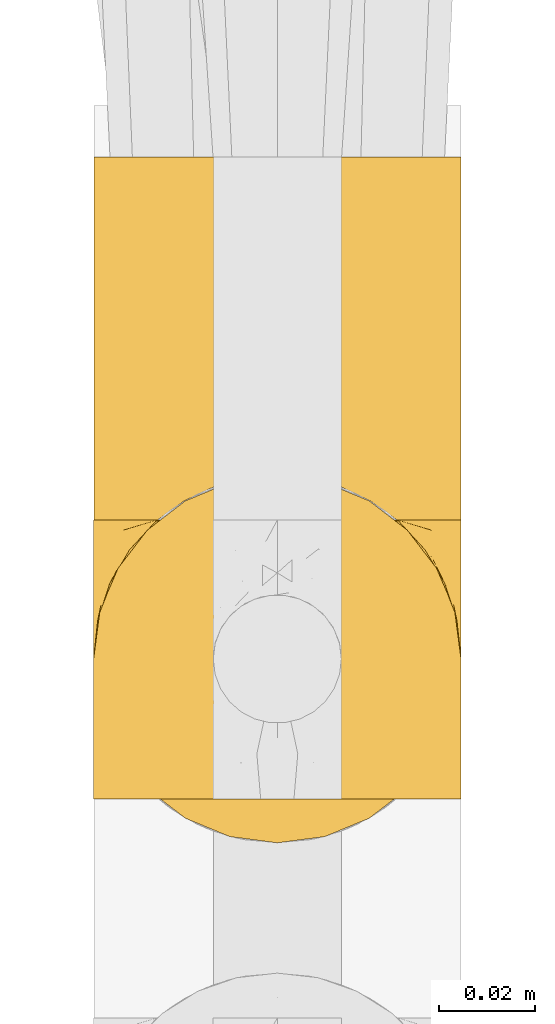
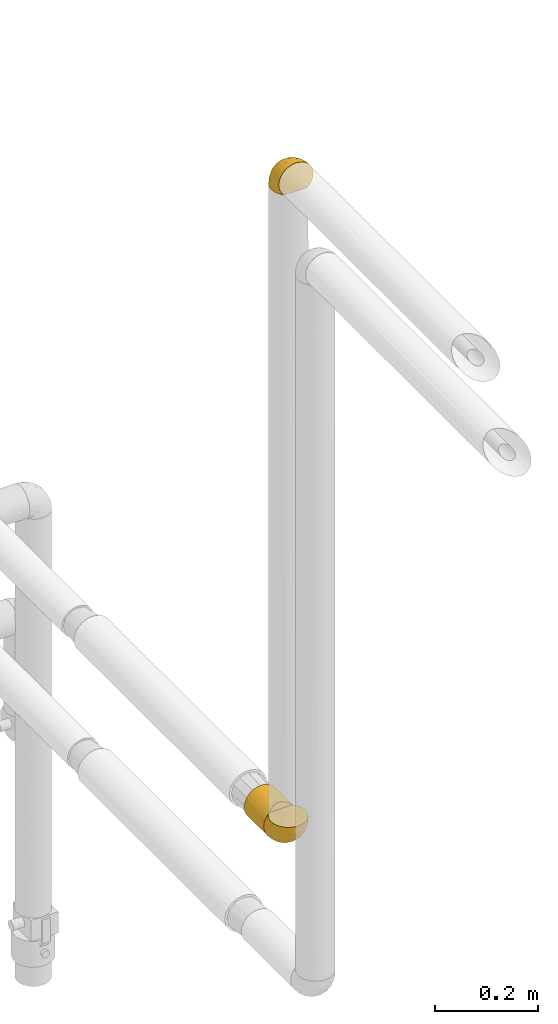
# One storey, part 61 of 827: 3 coverings.
"""IFC2X3 building model written with IfcOpenShell, lengths in millimetres."""

import ifcopenshell
import ifcopenshell.guid

model = None  # the IFC model being written
_history = None  # IfcOwnerHistory: only IFC2X3 demands one
_inside = {}  # id of a spatial element -> (the spatial element, [elements in it])
_under = {}  # id of a project, library or spatial element -> (it, [spatial elements below it])
_declared = {}  # id of a project -> (the project, [libraries it declares])
_typed = {}  # id of a type object -> (the type object, [elements of that type])
_made_of = {}  # id of a material, layer set ... -> (it, [elements and type objects made of it])


def new_model(schema):
    """Start an empty IFC model of exactly this schema.

    Asked for "IFC4X3", IfcOpenShell would pick the latest addendum, in which some entities
    have other attributes; the version numbers below select the first issue.
    IFC2X3 requires an IfcOwnerHistory on every rooted entity: one is made here for all.
    """
    global model, _history
    if schema == "IFC4X3":
        model = ifcopenshell.file(schema_version=(4, 3, 0, 0))
    else:
        model = ifcopenshell.file(schema=schema)
    _inside.clear()
    _under.clear()
    _declared.clear()
    _typed.clear()
    _made_of.clear()
    _history = None
    if model.schema == "IFC2X3":
        org = make("IfcOrganization", Name="unknown")
        user = make(
            "IfcPersonAndOrganization",
            ThePerson=make("IfcPerson", FamilyName="unknown"),
            TheOrganization=org,
        )
        app = make(
            "IfcApplication",
            ApplicationDeveloper=org,
            Version="unknown",
            ApplicationFullName="unknown",
            ApplicationIdentifier="unknown",
        )
        _history = make(
            "IfcOwnerHistory",
            OwningUser=user,
            OwningApplication=app,
            ChangeAction="ADDED",
            CreationDate=0,
        )
    return model


def make(cls, **values):
    """One entity of the class cls with the attributes given. An attribute that is None is left unset."""
    return model.create_entity(
        cls, **{name: value for name, value in values.items() if value is not None}
    )


def entity(cls, *values):
    """Any entity or typed value of the class cls, its attributes in the order of the schema. None: left unset."""
    e = model.create_entity(cls)
    for i, value in enumerate(values):
        if value is not None:
            e[i] = value
    return e


def rooted(cls, **values):
    """An entity with a GlobalId (a new one), such as an element, a storey or a relation."""
    return make(cls, GlobalId=ifcopenshell.guid.new(), OwnerHistory=_history, **values)


def si_unit(unit_type, name, prefix=None):
    """IfcSIUnit, for example si_unit("LENGTHUNIT", "METRE", prefix="MILLI")."""
    return make("IfcSIUnit", UnitType=unit_type, Prefix=prefix, Name=name)


def converted_unit(unit_type, name, factor, base, dimensions=None, offset=None):
    """IfcConversionBasedUnit, such as the inch: factor (a typed value) times the base unit."""
    return make(
        "IfcConversionBasedUnit"
        if offset is None
        else "IfcConversionBasedUnitWithOffset",
        ConversionOffset=offset,
        Dimensions=None
        if dimensions is None
        else entity("IfcDimensionalExponents", *dimensions),
        UnitType=unit_type,
        Name=name,
        ConversionFactor=make(
            "IfcMeasureWithUnit", ValueComponent=factor, UnitComponent=base
        ),
    )


def derived_unit(unit_type, elements):
    """IfcDerivedUnit: a product of units, each with its exponent."""
    return make(
        "IfcDerivedUnit",
        Elements=[
            make("IfcDerivedUnitElement", Unit=unit, Exponent=power)
            for unit, power in elements
        ],
        UnitType=unit_type,
    )


def assignment(units):
    """IfcUnitAssignment: the units of a project."""
    return None if units is None else make("IfcUnitAssignment", Units=units)


def point(xyz):
    """IfcCartesianPoint."""
    return None if xyz is None else make("IfcCartesianPoint", Coordinates=xyz)


def direction(xyz):
    """IfcDirection."""
    return None if xyz is None else make("IfcDirection", DirectionRatios=xyz)


def frame(location, z_axis=None, x_axis=None):
    """IfcAxis2Placement3D, a coordinate frame: its origin and axes. An axis left out is left unset."""
    return make(
        "IfcAxis2Placement3D",
        Location=point(location),
        Axis=direction(z_axis),
        RefDirection=direction(x_axis),
    )


def origin():
    """The frame at (0, 0, 0) with its axes left unset."""
    return frame((0.0, 0.0, 0.0))


def place(relative_to, where):
    """IfcLocalPlacement: puts the frame where relative to a parent placement (None: the world)."""
    return make(
        "IfcLocalPlacement", PlacementRelTo=relative_to, RelativePlacement=where
    )


def context(
    kind, dimensions, precision=None, world=None, true_north=None, identifier=None
):
    """IfcGeometricRepresentationContext, for example the 3D "Model" context."""
    return make(
        "IfcGeometricRepresentationContext",
        ContextIdentifier=identifier,
        ContextType=kind,
        CoordinateSpaceDimension=dimensions,
        Precision=precision,
        WorldCoordinateSystem=world,
        TrueNorth=true_north,
    )


def subcontext(parent, identifier, kind, view, scale=None):
    """IfcGeometricRepresentationSubContext, for example "Body" below "Model"."""
    return make(
        "IfcGeometricRepresentationSubContext",
        ContextIdentifier=identifier,
        ContextType=kind,
        ParentContext=parent,
        TargetScale=scale,
        TargetView=view,
    )


def project(units=None, contexts=None):
    """IfcProject with its units and contexts."""
    return rooted(
        "IfcProject",
        Name="project",
        RepresentationContexts=contexts,
        UnitsInContext=assignment(units),
    )


def spatial(cls, under=None, at=None, **own):
    """A site, building, storey or space (cls), placed at a placement, below another one or the project."""
    s = rooted(cls, ObjectPlacement=at, **own)
    if under is not None:
        _under.setdefault(under.id(), (under, []))[1].append(s)
    return s


def faces_of(points, faces, orient=None, outer=None):
    """IfcFace entities. A face is a list of loops; a loop is a list of indices into points, from 0.

    orient and outer hold one flag for each loop. By default every Orientation is true, the
    first loop of a face is its IfcFaceOuterBound and the others are IfcFaceBound.
    """
    made = []
    for i, loops in enumerate(faces):
        bounds = []
        for j, loop in enumerate(loops):
            is_outer = j == 0 if outer is None else outer[i][j]
            bounds.append(
                make(
                    "IfcFaceOuterBound" if is_outer else "IfcFaceBound",
                    Bound=make("IfcPolyLoop", Polygon=[points[k] for k in loop]),
                    Orientation=True if orient is None else orient[i][j],
                )
            )
        made.append(make("IfcFace", Bounds=bounds))
    return made


def faceted_brep(points, faces, orient=None, outer=None, voids=None):
    """IfcFacetedBrep: a solid bounded by flat faces; with voids (closed shells), ...WithVoids."""
    shared = [point(p) for p in points]
    hull = make("IfcClosedShell", CfsFaces=faces_of(shared, faces, orient, outer))
    if voids is None:
        return make("IfcFacetedBrep", Outer=hull)
    return make(
        "IfcFacetedBrepWithVoids",
        Outer=hull,
        Voids=[
            make(cls, CfsFaces=faces_of(shared, fs, o, b)) for cls, fs, o, b in voids
        ],
    )


def shape(context_of_items, identifier, shape_type, items):
    """IfcShapeRepresentation: the items that make up one representation, for example the "Body"."""
    return make(
        "IfcShapeRepresentation",
        ContextOfItems=context_of_items,
        RepresentationIdentifier=identifier,
        RepresentationType=shape_type,
        Items=items,
    )


def made_of(thing, what):
    """Note that an element or type object is made of a material, layer set ...; save() writes the relation."""
    if what is not None:
        _made_of.setdefault(what.id(), (what, []))[1].append(thing)
    return thing


def element(
    cls,
    number,
    at=None,
    inside=None,
    cuts=None,
    type_object=None,
    material=None,
    context=None,
    identifier="Body",
    shape_type=None,
    held_by="IfcProductDefinitionShape",
    body=None,
    shapes=None,
    **own,
):
    """One element of the class cls, such as IfcWall. Its Tag is "e" and its number.

    at: its placement. inside: the storey or other place that contains it. cuts: it is an
    opening in that element (IfcRelVoidsElement). A single representation is given by context,
    identifier, shape_type and body (its items); several are given by shapes. held_by: the class
    of the entity that holds the representations. save() writes the other relations.
    """
    e = rooted(cls, Tag="e%d" % number, ObjectPlacement=at, **own)
    if body is not None:
        shapes = [shape(context, identifier, shape_type, body)]
    if shapes is not None:
        e.Representation = make(held_by, Representations=shapes)
    if inside is not None:
        _inside.setdefault(inside.id(), (inside, []))[1].append(e)
    if cuts is not None:
        rooted(
            "IfcRelVoidsElement", RelatingBuildingElement=cuts, RelatedOpeningElement=e
        )
    if type_object is not None:
        _typed.setdefault(type_object.id(), (type_object, []))[1].append(e)
    return made_of(e, material)


def aggregate(whole, parts):
    """IfcRelAggregates: a whole, such as a stair, and the parts it consists of."""
    return rooted("IfcRelAggregates", RelatingObject=whole, RelatedObjects=parts)


def save(model, path):
    """Write the relations noted so far, then the file.

    IfcRelAggregates (storeys below a building ...), IfcRelContainedInSpatialStructure (elements
    in a storey), IfcRelDefinesByType, IfcRelAssociatesMaterial and IfcRelDeclares: one each for
    every whole, place, type object, material and project.
    """
    for whole, parts in _under.values():
        aggregate(whole, parts)
    for where, things in _inside.values():
        rooted(
            "IfcRelContainedInSpatialStructure",
            RelatedElements=things,
            RelatingStructure=where,
        )
    for kind, things in _typed.values():
        rooted("IfcRelDefinesByType", RelatedObjects=things, RelatingType=kind)
    for what, things in _made_of.values():
        rooted("IfcRelAssociatesMaterial", RelatedObjects=things, RelatingMaterial=what)
    for by, libraries in _declared.values():
        rooted("IfcRelDeclares", RelatingContext=by, RelatedDefinitions=libraries)
    model.write(path)


model = new_model("IFC2X3")

# Units and contexts
model_context = context("Model", 3, precision=0.01, world=origin(), true_north=direction((6.12303176911189e-17, 1.0)))
body_context = subcontext(model_context, "Body", "Model", "MODEL_VIEW")
ifc_project = project(units=[si_unit("LENGTHUNIT", "METRE", prefix="MILLI"), si_unit("AREAUNIT", "SQUARE_METRE"), si_unit("VOLUMEUNIT", "CUBIC_METRE"), converted_unit("PLANEANGLEUNIT", "DEGREE", entity("IfcRatioMeasure", 0.0174532925199433), si_unit("PLANEANGLEUNIT", "RADIAN"), dimensions=[0, 0, 0, 0, 0, 0, 0]), si_unit("MASSUNIT", "GRAM", prefix="KILO"), derived_unit("MASSDENSITYUNIT", [(si_unit("MASSUNIT", "GRAM", prefix="KILO"), 1), (si_unit("LENGTHUNIT", "METRE"), -3)]), derived_unit("MOMENTOFINERTIAUNIT", [(si_unit("LENGTHUNIT", "METRE"), 4)]), si_unit("TIMEUNIT", "SECOND"), si_unit("FREQUENCYUNIT", "HERTZ"), si_unit("THERMODYNAMICTEMPERATUREUNIT", "DEGREE_CELSIUS"), derived_unit("THERMALTRANSMITTANCEUNIT", [(si_unit("MASSUNIT", "GRAM", prefix="KILO"), 1), (si_unit("THERMODYNAMICTEMPERATUREUNIT", "KELVIN"), -1), (si_unit("TIMEUNIT", "SECOND"), -3)]), derived_unit("VOLUMETRICFLOWRATEUNIT", [(si_unit("LENGTHUNIT", "METRE"), 3), (si_unit("TIMEUNIT", "SECOND"), -1)]), derived_unit("MASSFLOWRATEUNIT", [(si_unit("MASSUNIT", "GRAM", prefix="KILO"), 1), (si_unit("TIMEUNIT", "SECOND"), -1)]), derived_unit("ROTATIONALFREQUENCYUNIT", [(si_unit("TIMEUNIT", "SECOND"), -1)]), si_unit("ELECTRICCURRENTUNIT", "AMPERE"), si_unit("ELECTRICVOLTAGEUNIT", "VOLT"), si_unit("POWERUNIT", "WATT"), si_unit("FORCEUNIT", "NEWTON", prefix="KILO"), si_unit("ILLUMINANCEUNIT", "LUX"), si_unit("LUMINOUSFLUXUNIT", "LUMEN"), si_unit("LUMINOUSINTENSITYUNIT", "CANDELA"), derived_unit("USERDEFINED", [(si_unit("MASSUNIT", "GRAM", prefix="KILO"), -1), (si_unit("LENGTHUNIT", "METRE"), -2), (si_unit("TIMEUNIT", "SECOND"), 3), (si_unit("LUMINOUSFLUXUNIT", "LUMEN"), 1)]), derived_unit("LINEARVELOCITYUNIT", [(si_unit("LENGTHUNIT", "METRE"), 1), (si_unit("TIMEUNIT", "SECOND"), -1)]), si_unit("PRESSUREUNIT", "PASCAL"), derived_unit("USERDEFINED", [(si_unit("LENGTHUNIT", "METRE"), -2), (si_unit("MASSUNIT", "GRAM", prefix="KILO"), 1), (si_unit("TIMEUNIT", "SECOND"), -2)]), derived_unit("LINEARFORCEUNIT", [(si_unit("MASSUNIT", "GRAM", prefix="KILO"), 1), (si_unit("LENGTHUNIT", "METRE"), 1), (si_unit("TIMEUNIT", "SECOND"), -2), (si_unit("LENGTHUNIT", "METRE"), -1)]), derived_unit("PLANARFORCEUNIT", [(si_unit("MASSUNIT", "GRAM", prefix="KILO"), 1), (si_unit("LENGTHUNIT", "METRE"), 1), (si_unit("TIMEUNIT", "SECOND"), -2), (si_unit("LENGTHUNIT", "METRE"), -2)])], contexts=[model_context])

# Site, building, storey
site_placement = place(None, origin())
site = spatial("IfcSite", under=ifc_project, at=site_placement, CompositionType="ELEMENT")
building_placement = place(site_placement, origin())
building = spatial("IfcBuilding", under=site, at=building_placement, CompositionType="ELEMENT")
storey_placement = place(building_placement, frame((0.0, 0.0, 28200.0)))
storey = spatial("IfcBuildingStorey", under=building, at=storey_placement, Name="08", CompositionType="ELEMENT", Elevation=28200.0)

# Coverings
covering_1_placement = place(storey_placement, frame((13238.8, 11192.04, 1260.0)))
element("IfcCovering", 1, at=covering_1_placement, inside=storey, Name=":ADSK_", ObjectType=":ADSK_", PredefinedType="INSULATION", context=body_context, shape_type="Brep", body=[
    faceted_brep([(20.8, 1.6, 6.74), (30.06, 1.6, 2.9), (40.0, 1.6, 1.6), (49.93, 1.6, 2.9), (59.2, 1.6, 6.74), (67.15, 1.6, 12.84), (73.25, 1.6, 20.8), (77.09, 1.6, 30.06), (78.4, 1.6, 40.0), (77.51, 1.6, 48.2), (74.9, 1.6, 56.01), (70.68, 1.6, 63.08), (65.05, 1.6, 69.1), (14.94, 1.6, 69.1), (9.31, 1.6, 63.08), (5.09, 1.6, 56.01), (2.48, 1.6, 48.2), (1.6, 1.6, 40.0), (2.9, 1.6, 30.06), (6.74, 1.6, 20.8), (12.84, 1.6, 12.84), (20.8, 77.5, 6.74), (12.84, 77.5, 12.84), (6.74, 77.5, 20.8), (2.9, 77.5, 30.06), (1.6, 77.5, 40.0), (2.9, 77.5, 49.93), (6.74, 77.5, 59.2), (12.84, 77.5, 67.15), (20.8, 77.5, 73.25), (30.06, 77.5, 77.09), (40.0, 77.5, 78.4), (49.93, 77.5, 77.09), (59.2, 77.5, 73.25), (67.15, 77.5, 67.15), (73.25, 77.5, 59.2), (77.09, 77.5, 49.93), (78.4, 77.5, 40.0), (77.09, 77.5, 30.06), (73.25, 77.5, 20.8), (67.15, 77.5, 12.84), (59.2, 77.5, 6.74), (49.93, 77.5, 2.9), (40.0, 77.5, 1.6), (30.06, 77.5, 2.9), (53.36, 8.5, 76.0), (46.78, 10.29, 77.79), (40.0, 10.9, 78.4), (59.51, 5.57, 73.07), (33.21, 10.29, 77.79), (26.63, 8.5, 76.0), (20.48, 5.57, 73.07)], [[[0, 1, 2, 3, 4, 5, 6, 7, 8, 9, 10, 11, 12, 13, 14, 15, 16, 17, 18, 19, 20]], [[21, 22, 23, 24, 25, 26, 27, 28, 29, 30, 31, 32, 33, 34, 35, 36, 37, 38, 39, 40, 41, 42, 43, 44]], [[24, 23, 19, 18]], [[25, 24, 18, 17]], [[20, 19, 23, 22]], [[1, 0, 21, 44]], [[2, 1, 44, 43]], [[22, 21, 0, 20]], [[3, 2, 43, 42]], [[4, 3, 42, 41]], [[41, 40, 5, 4]], [[7, 6, 39, 38]], [[8, 7, 38, 37]], [[40, 39, 6, 5]], [[9, 37, 36]], [[10, 36, 35]], [[11, 35, 34]], [[8, 37, 9]], [[9, 36, 10]], [[35, 11, 10]], [[34, 12, 11]], [[45, 33, 32]], [[32, 31, 46]], [[47, 46, 31]], [[48, 12, 33]], [[46, 45, 32]], [[48, 33, 45]], [[33, 12, 34]], [[49, 47, 31]], [[49, 31, 30]], [[50, 30, 29]], [[50, 49, 30]], [[13, 51, 29]], [[50, 29, 51]], [[29, 28, 13]], [[14, 28, 27]], [[15, 27, 26]], [[16, 26, 25]], [[14, 27, 15]], [[15, 26, 16]], [[25, 17, 16]], [[28, 14, 13]], [[48, 45, 46, 47, 49, 50, 51, 13, 12]]]),
])
covering_2_placement = place(storey_placement, frame((13238.75, 11124.49, 1259.95)))
element("IfcCovering", 2, at=covering_2_placement, inside=storey, Name=":ADSK_", ObjectType=":ADSK_", PredefinedType="INSULATION", context=body_context, shape_type="Brep", body=[
    faceted_brep([(74.68, 69.15, 23.36), (70.1, 69.15, 16.07), (64.01, 69.15, 9.98), (56.72, 69.15, 5.4), (48.6, 69.15, 2.56), (40.05, 69.15, 1.6), (31.49, 69.15, 2.56), (23.36, 69.15, 5.41), (16.07, 69.15, 9.99), (9.98, 69.15, 16.08), (5.4, 69.15, 23.37), (2.56, 69.15, 31.49), (1.6, 69.15, 40.05), (2.46, 69.15, 48.15), (5.01, 69.15, 55.88), (9.13, 69.15, 62.9), (14.62, 69.15, 68.89), (16.82, 69.15, 68.89), (18.56, 69.15, 68.89), (20.52, 69.15, 68.89), (22.49, 69.15, 68.89), (24.46, 69.15, 68.89), (26.42, 69.15, 68.89), (28.39, 69.15, 68.89), (30.36, 69.15, 68.89), (32.55, 69.15, 68.89), (34.75, 69.15, 68.89), (36.94, 69.15, 68.89), (39.13, 69.15, 68.89), (41.33, 69.15, 68.89), (43.52, 69.15, 68.89), (45.72, 69.15, 68.89), (47.91, 69.15, 68.89), (50.11, 69.15, 68.89), (52.3, 69.15, 68.89), (54.49, 69.15, 68.89), (56.69, 69.15, 68.89), (58.88, 69.15, 68.89), (61.08, 69.15, 68.89), (63.27, 69.15, 68.89), (65.47, 69.15, 68.89), (70.97, 69.15, 62.89), (75.09, 69.15, 55.86), (77.64, 69.15, 48.13), (78.5, 69.15, 40.05), (77.53, 69.15, 31.49), (14.62, 68.89, 69.15), (9.12, 62.89, 69.15), (5.0, 55.87, 69.15), (2.46, 48.14, 69.15), (1.6, 40.05, 69.15), (2.91, 30.09, 69.15), (6.75, 20.82, 69.15), (12.86, 12.86, 69.15), (20.82, 6.75, 69.15), (30.09, 2.91, 69.15), (40.05, 1.6, 69.15), (50.0, 2.91, 69.15), (59.27, 6.75, 69.15), (67.23, 12.86, 69.15), (73.34, 20.82, 69.15), (77.19, 30.09, 69.15), (78.5, 40.05, 69.15), (77.63, 48.14, 69.15), (75.09, 55.87, 69.15), (70.97, 62.89, 69.15), (65.47, 68.89, 69.15), (63.27, 68.89, 69.15), (62.29, 68.89, 69.15), (60.7, 68.89, 69.15), (59.11, 68.89, 69.15), (57.52, 68.89, 69.15), (55.93, 68.89, 69.15), (54.34, 68.89, 69.15), (52.76, 68.89, 69.15), (51.17, 68.89, 69.15), (49.58, 68.89, 69.15), (47.99, 68.89, 69.15), (46.4, 68.89, 69.15), (44.81, 68.89, 69.15), (43.22, 68.89, 69.15), (41.63, 68.89, 69.15), (40.05, 68.89, 69.15), (38.46, 68.89, 69.15), (36.87, 68.89, 69.15), (35.28, 68.89, 69.15), (33.69, 68.89, 69.15), (32.1, 68.89, 69.15), (30.51, 68.89, 69.15), (28.92, 68.89, 69.15), (27.33, 68.89, 69.15), (25.37, 68.89, 69.15), (23.4, 68.89, 69.15), (21.21, 68.89, 69.15), (19.01, 68.89, 69.15), (16.82, 68.89, 69.15), (42.32, 68.97, 68.96), (44.02, 68.96, 68.97), (47.13, 68.97, 68.97), (48.74, 68.97, 68.97), (23.57, 68.98, 68.95), (25.13, 68.97, 68.96), (61.34, 68.96, 68.98), (22.02, 68.96, 68.97), (29.72, 68.96, 68.97), (56.73, 68.96, 68.98), (55.14, 68.96, 68.97), (37.66, 68.96, 68.97), (64.12, 69.0, 68.94), (28.13, 68.96, 68.98), (26.62, 68.96, 68.98), (31.46, 68.97, 68.96), (16.16, 68.96, 68.97), (39.16, 68.96, 68.98), (50.37, 68.96, 68.98), (17.69, 68.97, 68.97), (19.17, 68.97, 68.96), (62.78, 68.97, 68.97), (58.35, 68.96, 68.97), (45.53, 68.96, 68.98), (59.91, 68.97, 68.96), (65.47, 68.97, 68.97), (65.47, 69.02, 68.94), (65.47, 69.08, 68.92), (14.62, 68.97, 68.97), (14.62, 68.94, 69.02), (14.62, 68.92, 69.08), (20.59, 68.96, 68.98), (32.99, 68.96, 68.97), (34.48, 68.95, 68.98), (51.91, 68.96, 68.97), (65.47, 68.92, 69.08), (65.47, 68.94, 69.02), (53.48, 68.98, 68.96), (14.62, 69.08, 68.92), (14.62, 69.02, 68.94), (40.77, 68.96, 68.97), (35.97, 68.97, 68.96), (7.84, 61.33, 67.02), (3.53, 53.1, 63.33), (8.32, 63.33, 64.61), (1.6, 49.27, 49.27), (2.19, 55.53, 51.4), (1.6, 54.6, 43.94), (1.6, 41.99, 61.87), (4.57, 57.07, 61.54), (3.96, 57.95, 57.95), (2.28, 51.56, 56.12), (1.6, 41.58, 63.4), (7.69, 61.7, 65.41), (3.53, 63.33, 53.1), (8.32, 65.0, 63.04), (7.84, 67.02, 61.33), (1.6, 61.87, 41.99), (1.6, 43.94, 54.6), (4.34, 61.21, 56.6), (1.6, 63.4, 41.58), (29.63, 33.11, 13.72), (27.34, 52.82, 5.82), (40.05, 43.3, 6.74), (2.39, 33.73, 58.82), (2.43, 36.52, 51.58), (9.07, 24.87, 42.09), (16.64, 14.17, 46.12), (9.54, 18.43, 55.56), (4.52, 28.67, 52.38), (4.52, 26.0, 61.54), (7.49, 49.25, 23.76), (7.49, 59.72, 20.5), (12.85, 55.1, 14.64), (2.35, 44.72, 41.77), (22.66, 34.15, 16.28), (32.9, 5.25, 49.4), (25.33, 6.75, 52.34), (40.05, 55.54, 4.3), (16.64, 10.47, 58.67), (19.99, 25.49, 25.26), (16.37, 35.53, 20.17), (3.26, 48.22, 34.7), (3.75, 58.71, 28.67), (19.58, 57.42, 8.62), (7.5, 34.84, 33.37), (4.04, 36.87, 41.35), (13.94, 45.01, 17.15), (19.58, 44.4, 12.68), (28.21, 23.96, 21.47), (24.75, 11.2, 41.11), (31.42, 10.56, 37.53), (26.2, 16.81, 30.64), (33.36, 17.38, 26.66), (40.05, 21.38, 21.38), (40.05, 32.34, 14.06), (40.05, 4.3, 55.54), (16.14, 20.65, 35.17), (12.85, 29.66, 29.04), (10.47, 39.6, 24.34), (6.49, 42.55, 29.33), (40.05, 6.74, 43.3), (40.05, 14.06, 32.34), (75.57, 26.84, 57.75), (47.37, 5.28, 49.41), (52.91, 18.52, 27.85), (50.46, 33.13, 13.7), (67.23, 55.1, 14.63), (60.5, 57.43, 8.61), (70.55, 20.72, 48.85), (63.45, 11.46, 54.13), (62.61, 17.69, 37.84), (72.6, 49.26, 23.75), (72.6, 59.73, 20.49), (76.34, 58.71, 28.66), (59.34, 29.72, 20.83), (77.76, 35.35, 55.15), (78.5, 43.94, 54.6), (78.5, 41.99, 61.87), (78.5, 63.4, 41.58), (53.16, 4.93, 57.58), (70.55, 17.46, 59.91), (48.88, 10.94, 36.94), (54.76, 8.92, 45.72), (52.74, 52.83, 5.82), (71.93, 29.34, 37.91), (75.79, 30.26, 50.18), (60.5, 44.4, 12.67), (77.86, 39.06, 49.29), (77.64, 43.06, 42.64), (78.5, 54.6, 43.94), (78.5, 49.27, 49.27), (67.23, 42.69, 19.45), (76.82, 48.2, 34.7), (78.5, 61.87, 41.99), (77.8, 33.44, 62.29), (67.23, 29.67, 29.01), (73.2, 38.5, 31.47), (67.66, 23.35, 37.18), (75.99, 34.97, 43.45), (76.57, 53.1, 63.33), (73.21, 59.68, 67.23), (71.93, 62.19, 66.07), (71.07, 64.11, 65.22), (75.09, 57.97, 61.99), (76.13, 57.95, 57.95), (76.57, 63.33, 53.09), (77.69, 51.77, 56.84), (72.26, 67.02, 61.33), (71.77, 64.98, 63.06), (77.9, 55.53, 51.41), (75.75, 61.22, 56.61)], [[[0, 1, 2, 3, 4, 5, 6, 7, 8, 9, 10, 11, 12, 13, 14, 15, 16, 17, 18, 19, 20, 21, 22, 23, 24, 25, 26, 27, 28, 29, 30, 31, 32, 33, 34, 35, 36, 37, 38, 39, 40, 41, 42, 43, 44, 45]], [[46, 47, 48, 49, 50, 51, 52, 53, 54, 55, 56, 57, 58, 59, 60, 61, 62, 63, 64, 65, 66, 67, 68, 69, 70, 71, 72, 73, 74, 75, 76, 77, 78, 79, 80, 81, 82, 83, 84, 85, 86, 87, 88, 89, 90, 91, 92, 93, 94, 95]], [[96, 97, 30]], [[98, 77, 99]], [[100, 101, 21]], [[69, 68, 102]], [[20, 19, 103]], [[24, 23, 104]], [[20, 103, 100]], [[72, 105, 106]], [[84, 83, 107]], [[89, 88, 104]], [[108, 67, 66]], [[109, 110, 90]], [[111, 25, 24]], [[112, 17, 16]], [[82, 113, 83]], [[109, 23, 22]], [[114, 76, 75]], [[105, 36, 106]], [[104, 111, 24]], [[18, 115, 116]], [[97, 96, 80]], [[67, 108, 117]], [[105, 71, 118]], [[31, 97, 119]], [[102, 120, 69]], [[108, 121, 122, 123, 40]], [[112, 95, 115]], [[17, 115, 18]], [[94, 116, 115]], [[117, 68, 67]], [[38, 117, 39]], [[112, 124, 125, 126, 46]], [[17, 112, 115]], [[70, 120, 118]], [[39, 117, 108]], [[120, 38, 37]], [[120, 37, 118]], [[120, 70, 69]], [[116, 94, 127]], [[128, 86, 129]], [[117, 38, 102]], [[74, 130, 75]], [[99, 33, 32]], [[115, 95, 94]], [[39, 108, 40]], [[108, 66, 131, 132, 121]], [[105, 72, 71]], [[118, 37, 36]], [[71, 70, 118]], [[35, 106, 36]], [[36, 105, 118]], [[35, 133, 106]], [[74, 73, 133]], [[106, 133, 73]], [[99, 114, 33]], [[133, 35, 34]], [[73, 72, 106]], [[95, 112, 46]], [[112, 16, 134, 135, 124]], [[130, 114, 75]], [[99, 76, 114]], [[114, 130, 33]], [[34, 33, 130]], [[78, 77, 98]], [[98, 119, 78]], [[130, 133, 34]], [[133, 130, 74]], [[79, 97, 80]], [[98, 99, 32]], [[98, 32, 31]], [[77, 76, 99]], [[97, 79, 119]], [[136, 96, 29]], [[30, 97, 31]], [[136, 29, 28]], [[81, 80, 96]], [[29, 96, 30]], [[31, 119, 98]], [[119, 79, 78]], [[96, 136, 81]], [[82, 81, 136]], [[113, 107, 83]], [[84, 107, 137]], [[107, 27, 137]], [[113, 28, 107]], [[27, 107, 28]], [[85, 84, 137]], [[137, 27, 26]], [[113, 136, 28]], [[136, 113, 82]], [[109, 89, 104]], [[86, 85, 129]], [[89, 109, 90]], [[111, 87, 128]], [[26, 129, 137]], [[88, 111, 104]], [[25, 111, 128]], [[22, 110, 109]], [[23, 109, 104]], [[110, 91, 90]], [[100, 92, 101]], [[110, 22, 101]], [[91, 110, 101]], [[116, 19, 18]], [[111, 88, 87]], [[127, 103, 19]], [[25, 128, 26]], [[86, 128, 87]], [[128, 129, 26]], [[137, 129, 85]], [[120, 102, 38]], [[117, 102, 68]], [[91, 101, 92]], [[21, 101, 22]], [[93, 92, 103]], [[100, 21, 20]], [[100, 103, 92]], [[127, 93, 103]], [[93, 127, 94]], [[116, 127, 19]], [[126, 138, 47]], [[48, 138, 139]], [[140, 125, 124]], [[141, 142, 143]], [[144, 49, 139]], [[145, 140, 146]], [[48, 139, 49]], [[139, 145, 147]], [[49, 144, 148, 50]], [[126, 125, 149]], [[14, 13, 150]], [[151, 146, 140]], [[149, 140, 145]], [[152, 151, 135]], [[152, 14, 150]], [[16, 15, 134]], [[13, 153, 150]], [[124, 151, 140]], [[141, 147, 142]], [[14, 152, 15]], [[15, 152, 134]], [[47, 46, 126]], [[139, 154, 144]], [[138, 48, 47]], [[125, 140, 149]], [[135, 134, 152]], [[146, 155, 142]], [[145, 146, 147]], [[149, 139, 138]], [[147, 141, 154]], [[147, 146, 142]], [[139, 147, 154]], [[139, 149, 145]], [[149, 138, 126]], [[155, 146, 151]], [[150, 143, 142]], [[152, 155, 151]], [[150, 142, 155]], [[13, 12, 156, 153]], [[153, 143, 150]], [[152, 150, 155]], [[151, 124, 135]], [[157, 158, 159]], [[160, 154, 161]], [[162, 163, 164]], [[165, 166, 160]], [[167, 168, 169]], [[141, 170, 161]], [[156, 12, 11]], [[158, 157, 171]], [[172, 55, 173]], [[158, 6, 174]], [[175, 54, 53]], [[52, 166, 164]], [[52, 164, 53]], [[54, 175, 173]], [[166, 52, 51]], [[176, 177, 171]], [[178, 143, 179]], [[156, 11, 179]], [[8, 7, 180]], [[169, 9, 8]], [[179, 143, 153, 156]], [[179, 11, 10]], [[168, 179, 10]], [[181, 162, 182]], [[179, 167, 178]], [[183, 184, 177]], [[183, 169, 184]], [[176, 171, 185]], [[172, 186, 187]], [[158, 7, 6]], [[159, 158, 174]], [[184, 180, 158]], [[54, 173, 55]], [[180, 169, 8]], [[188, 189, 187]], [[9, 168, 10]], [[186, 188, 187]], [[190, 157, 159, 191]], [[55, 172, 192]], [[176, 193, 194]], [[161, 170, 182]], [[162, 164, 165]], [[175, 164, 163]], [[51, 50, 148]], [[167, 195, 196]], [[178, 182, 170]], [[6, 5, 174]], [[158, 180, 7]], [[169, 180, 184]], [[169, 168, 9]], [[179, 168, 167]], [[182, 162, 165]], [[162, 194, 193]], [[161, 165, 160]], [[195, 181, 196]], [[192, 172, 197]], [[192, 56, 55]], [[189, 190, 198]], [[198, 197, 187]], [[172, 187, 197]], [[185, 189, 188]], [[198, 187, 189]], [[186, 172, 173]], [[173, 163, 186]], [[193, 186, 163]], [[176, 185, 188]], [[185, 157, 190]], [[188, 186, 193]], [[177, 176, 194]], [[188, 193, 176]], [[162, 193, 163]], [[195, 177, 194]], [[171, 177, 184]], [[181, 195, 194]], [[183, 167, 169]], [[162, 181, 194]], [[196, 182, 178]], [[158, 171, 184]], [[171, 157, 185]], [[177, 195, 183]], [[167, 183, 195]], [[182, 196, 181]], [[178, 170, 143]], [[178, 167, 196]], [[164, 175, 53]], [[173, 175, 163]], [[160, 51, 148]], [[164, 166, 165]], [[51, 160, 166]], [[160, 148, 144, 154]], [[141, 161, 154]], [[182, 165, 161]], [[190, 189, 185]], [[143, 170, 141]], [[60, 199, 61]], [[197, 200, 192]], [[201, 190, 202]], [[200, 57, 192]], [[203, 204, 2]], [[205, 206, 207]], [[208, 209, 210]], [[211, 207, 201]], [[212, 213, 214]], [[45, 215, 210]], [[216, 206, 58]], [[45, 44, 215]], [[59, 217, 60]], [[60, 217, 199]], [[0, 45, 210]], [[218, 201, 219]], [[202, 159, 220]], [[205, 221, 222]], [[223, 204, 203]], [[1, 203, 2]], [[57, 200, 216]], [[220, 3, 204]], [[220, 174, 4]], [[1, 0, 209]], [[212, 224, 213]], [[225, 226, 227]], [[228, 223, 203]], [[208, 210, 229]], [[210, 226, 229]], [[3, 220, 4]], [[58, 206, 59]], [[209, 203, 1]], [[202, 220, 223]], [[228, 203, 208]], [[202, 211, 201]], [[3, 2, 204]], [[202, 190, 191, 159]], [[210, 215, 230, 226]], [[199, 212, 231]], [[232, 233, 221]], [[233, 208, 229]], [[207, 206, 219]], [[217, 206, 205]], [[227, 224, 225]], [[233, 232, 228]], [[201, 207, 219]], [[234, 232, 221]], [[218, 219, 200]], [[202, 223, 211]], [[174, 220, 159]], [[174, 5, 4]], [[61, 231, 62]], [[220, 204, 223]], [[210, 209, 0]], [[203, 209, 208]], [[225, 233, 229]], [[224, 227, 213]], [[221, 233, 235]], [[57, 56, 192]], [[198, 218, 197]], [[200, 219, 216]], [[201, 198, 190]], [[197, 218, 200]], [[198, 201, 218]], [[206, 216, 219]], [[58, 57, 216]], [[231, 212, 214]], [[222, 212, 199]], [[228, 211, 223]], [[207, 211, 232]], [[62, 231, 214]], [[199, 231, 61]], [[233, 228, 208]], [[211, 228, 232]], [[222, 221, 235]], [[234, 205, 207]], [[206, 217, 59]], [[199, 217, 205]], [[205, 222, 199]], [[224, 222, 235]], [[222, 224, 212]], [[224, 235, 225]], [[233, 225, 235]], [[226, 225, 229]], [[205, 234, 221]], [[207, 232, 234]], [[63, 214, 236]], [[214, 213, 236]], [[214, 63, 62]], [[237, 236, 238]], [[238, 132, 131]], [[236, 237, 64]], [[239, 240, 241]], [[63, 236, 64]], [[131, 66, 65]], [[237, 131, 65]], [[242, 230, 43]], [[237, 65, 64]], [[239, 121, 132]], [[42, 242, 43]], [[241, 240, 243]], [[41, 123, 244]], [[43, 230, 215, 44]], [[244, 122, 245]], [[227, 246, 243]], [[245, 241, 247]], [[121, 239, 245]], [[41, 40, 123]], [[132, 238, 239]], [[244, 42, 41]], [[131, 237, 238]], [[240, 239, 238]], [[245, 239, 241]], [[247, 241, 246]], [[247, 244, 245]], [[238, 236, 240]], [[243, 236, 213]], [[236, 243, 240]], [[246, 241, 243]], [[243, 213, 227]], [[226, 242, 246]], [[227, 226, 246]], [[246, 242, 247]], [[244, 247, 242]], [[242, 226, 230]], [[42, 244, 242]], [[122, 244, 123]], [[122, 121, 245]]]),
])
covering_3_placement = place(storey_placement, frame((13238.75, 11133.64, 2819.33)))
element("IfcCovering", 3, at=covering_3_placement, inside=storey, Name=":ADSK_", ObjectType=":ADSK_", PredefinedType="INSULATION", context=body_context, shape_type="Brep", body=[
    faceted_brep([(14.62, 1.6, 1.85), (16.82, 1.6, 1.85), (18.56, 1.6, 1.85), (20.52, 1.6, 1.85), (22.49, 1.6, 1.85), (24.46, 1.6, 1.85), (26.42, 1.6, 1.85), (28.39, 1.6, 1.85), (30.36, 1.6, 1.85), (32.55, 1.6, 1.85), (34.75, 1.6, 1.85), (36.94, 1.6, 1.85), (39.13, 1.6, 1.85), (41.33, 1.6, 1.85), (43.52, 1.6, 1.85), (45.72, 1.6, 1.85), (47.91, 1.6, 1.85), (50.11, 1.6, 1.85), (52.3, 1.6, 1.85), (54.49, 1.6, 1.85), (56.69, 1.6, 1.85), (58.88, 1.6, 1.85), (61.08, 1.6, 1.85), (63.27, 1.6, 1.85), (65.47, 1.6, 1.85), (70.97, 1.6, 7.85), (75.09, 1.6, 14.88), (77.64, 1.6, 22.61), (78.5, 1.6, 30.7), (77.53, 1.6, 39.26), (74.68, 1.6, 47.38), (70.1, 1.6, 54.67), (64.01, 1.6, 60.76), (56.72, 1.6, 65.34), (48.6, 1.6, 68.18), (40.05, 1.6, 69.15), (31.49, 1.6, 68.18), (23.36, 1.6, 65.33), (16.07, 1.6, 60.75), (9.98, 1.6, 54.66), (5.4, 1.6, 47.37), (2.56, 1.6, 39.25), (1.6, 1.6, 30.7), (2.46, 1.6, 22.59), (5.01, 1.6, 14.86), (9.13, 1.6, 7.84), (14.62, 1.85, 1.6), (9.12, 7.85, 1.6), (5.0, 14.87, 1.6), (2.46, 22.6, 1.6), (1.6, 30.7, 1.6), (2.91, 40.65, 1.6), (6.75, 49.92, 1.6), (12.86, 57.88, 1.6), (20.82, 64.0, 1.6), (30.09, 67.84, 1.6), (40.05, 69.15, 1.6), (50.0, 67.84, 1.6), (59.27, 64.0, 1.6), (67.23, 57.88, 1.6), (73.34, 49.92, 1.6), (77.19, 40.65, 1.6), (78.5, 30.7, 1.6), (77.63, 22.6, 1.6), (75.09, 14.87, 1.6), (70.97, 7.85, 1.6), (65.47, 1.85, 1.6), (63.27, 1.85, 1.6), (62.29, 1.85, 1.6), (60.7, 1.85, 1.6), (59.11, 1.85, 1.6), (57.52, 1.85, 1.6), (55.93, 1.85, 1.6), (54.34, 1.85, 1.6), (52.76, 1.85, 1.6), (51.17, 1.85, 1.6), (49.58, 1.85, 1.6), (47.99, 1.85, 1.6), (46.4, 1.85, 1.6), (44.81, 1.85, 1.6), (43.22, 1.85, 1.6), (41.63, 1.85, 1.6), (40.05, 1.85, 1.6), (38.46, 1.85, 1.6), (36.87, 1.85, 1.6), (35.28, 1.85, 1.6), (33.69, 1.85, 1.6), (32.1, 1.85, 1.6), (30.51, 1.85, 1.6), (28.92, 1.85, 1.6), (27.33, 1.85, 1.6), (25.37, 1.85, 1.6), (23.4, 1.85, 1.6), (21.21, 1.85, 1.6), (19.01, 1.85, 1.6), (16.82, 1.85, 1.6), (42.32, 1.77, 1.78), (44.02, 1.78, 1.77), (47.13, 1.77, 1.78), (48.74, 1.78, 1.77), (23.57, 1.76, 1.79), (25.13, 1.77, 1.78), (61.34, 1.79, 1.76), (22.02, 1.78, 1.77), (29.72, 1.78, 1.77), (56.73, 1.79, 1.76), (55.14, 1.78, 1.77), (37.66, 1.78, 1.77), (64.12, 1.74, 1.8), (28.13, 1.78, 1.76), (26.62, 1.78, 1.77), (31.46, 1.77, 1.78), (16.16, 1.78, 1.77), (39.16, 1.78, 1.77), (50.37, 1.78, 1.76), (17.69, 1.78, 1.77), (19.17, 1.77, 1.78), (62.78, 1.78, 1.77), (58.35, 1.78, 1.77), (45.53, 1.78, 1.77), (59.91, 1.77, 1.78), (65.47, 1.78, 1.77), (65.47, 1.72, 1.8), (65.47, 1.66, 1.82), (14.62, 1.78, 1.77), (14.62, 1.8, 1.72), (14.62, 1.82, 1.66), (20.59, 1.79, 1.76), (32.99, 1.78, 1.77), (34.48, 1.79, 1.76), (51.91, 1.78, 1.77), (65.47, 1.82, 1.66), (65.47, 1.8, 1.72), (53.48, 1.77, 1.78), (14.62, 1.66, 1.82), (14.62, 1.72, 1.8), (40.77, 1.78, 1.77), (35.97, 1.77, 1.78), (7.84, 9.41, 3.72), (3.53, 17.65, 7.41), (8.32, 7.41, 6.13), (2.19, 15.21, 19.34), (3.53, 7.41, 17.64), (1.6, 16.15, 26.8), (1.6, 28.75, 8.87), (4.57, 13.67, 9.2), (3.96, 12.79, 12.79), (2.28, 19.18, 14.62), (7.69, 9.04, 5.33), (8.32, 5.74, 7.7), (7.84, 3.72, 9.41), (1.6, 8.87, 28.75), (1.6, 21.47, 21.47), (1.6, 26.8, 16.15), (4.34, 9.54, 14.14), (1.6, 7.34, 29.16), (29.63, 37.63, 57.02), (27.34, 17.92, 64.92), (40.05, 27.45, 64.0), (2.45, 37.26, 11.99), (4.52, 44.75, 9.2), (4.52, 42.08, 18.36), (7.49, 21.49, 46.98), (7.49, 11.02, 50.24), (12.85, 15.64, 56.1), (19.99, 45.25, 45.49), (16.37, 35.21, 50.57), (22.67, 36.59, 54.46), (32.9, 65.5, 21.34), (25.33, 64.0, 18.4), (40.05, 15.2, 66.44), (16.64, 60.27, 12.07), (9.54, 52.31, 15.19), (2.35, 26.03, 28.97), (2.43, 34.22, 19.16), (3.26, 22.53, 36.04), (3.75, 12.03, 42.07), (19.58, 13.32, 62.12), (7.5, 35.9, 37.37), (9.07, 45.87, 28.65), (4.04, 33.87, 29.39), (13.94, 25.73, 53.59), (19.58, 26.34, 58.06), (28.21, 46.78, 49.27), (24.75, 59.55, 29.63), (31.42, 60.18, 33.21), (16.64, 56.57, 24.62), (26.2, 53.93, 40.1), (33.36, 53.36, 44.08), (40.05, 49.36, 49.36), (40.05, 38.4, 56.68), (40.05, 66.44, 15.2), (16.14, 50.09, 35.57), (12.85, 41.08, 41.7), (10.47, 31.14, 46.4), (6.49, 28.19, 41.41), (40.05, 64.0, 27.45), (40.05, 56.68, 38.4), (76.05, 33.87, 29.38), (72.59, 35.89, 37.39), (73.58, 28.19, 41.44), (47.19, 65.5, 21.34), (55.35, 59.54, 29.64), (54.76, 63.99, 18.41), (63.45, 56.57, 24.63), (63.45, 60.27, 12.08), (70.55, 52.31, 15.19), (46.73, 53.36, 44.08), (51.87, 46.77, 49.28), (53.88, 53.92, 40.11), (72.6, 21.48, 46.99), (72.6, 11.01, 50.25), (76.34, 12.03, 42.08), (60.09, 45.25, 45.5), (63.95, 50.09, 35.59), (78.5, 28.75, 8.87), (77.64, 37.26, 11.99), (77.66, 34.22, 19.16), (78.5, 7.34, 29.16), (75.57, 42.08, 18.36), (75.57, 44.75, 9.2), (50.46, 37.61, 57.04), (52.74, 17.91, 64.92), (60.5, 26.34, 58.07), (60.5, 13.31, 62.13), (67.23, 15.64, 56.11), (78.5, 26.8, 16.15), (67.23, 41.07, 41.73), (63.7, 35.21, 50.58), (69.61, 31.13, 46.42), (76.82, 22.54, 36.04), (78.5, 16.15, 26.8), (71.01, 45.86, 28.66), (66.14, 25.73, 53.61), (78.5, 8.87, 28.75), (48.67, 60.18, 33.21), (77.74, 26.03, 28.97), (78.5, 21.47, 21.47), (57.37, 37.65, 53.77), (76.57, 17.65, 7.41), (73.21, 11.06, 3.51), (71.93, 8.56, 4.68), (71.07, 6.63, 5.52), (75.09, 12.77, 8.75), (76.13, 12.79, 12.79), (76.57, 7.41, 17.65), (77.69, 18.97, 13.9), (72.26, 3.73, 9.42), (71.77, 5.77, 7.68), (77.9, 15.21, 19.33), (75.75, 9.52, 14.13)], [[[0, 1, 2, 3, 4, 5, 6, 7, 8, 9, 10, 11, 12, 13, 14, 15, 16, 17, 18, 19, 20, 21, 22, 23, 24, 25, 26, 27, 28, 29, 30, 31, 32, 33, 34, 35, 36, 37, 38, 39, 40, 41, 42, 43, 44, 45]], [[46, 47, 48, 49, 50, 51, 52, 53, 54, 55, 56, 57, 58, 59, 60, 61, 62, 63, 64, 65, 66, 67, 68, 69, 70, 71, 72, 73, 74, 75, 76, 77, 78, 79, 80, 81, 82, 83, 84, 85, 86, 87, 88, 89, 90, 91, 92, 93, 94, 95]], [[96, 97, 14]], [[98, 77, 99]], [[100, 101, 5]], [[69, 68, 102]], [[4, 3, 103]], [[8, 7, 104]], [[4, 103, 100]], [[72, 105, 106]], [[84, 83, 107]], [[89, 88, 104]], [[108, 67, 66]], [[109, 110, 90]], [[111, 9, 8]], [[112, 1, 0]], [[82, 113, 83]], [[109, 7, 6]], [[114, 76, 75]], [[105, 20, 106]], [[104, 111, 8]], [[2, 115, 116]], [[97, 96, 80]], [[67, 108, 117]], [[105, 71, 118]], [[15, 97, 119]], [[102, 120, 69]], [[108, 121, 122, 123, 24]], [[112, 95, 115]], [[1, 115, 2]], [[94, 116, 115]], [[117, 68, 67]], [[22, 117, 23]], [[112, 124, 125, 126, 46]], [[1, 112, 115]], [[70, 120, 118]], [[23, 117, 108]], [[120, 22, 21]], [[120, 21, 118]], [[120, 70, 69]], [[116, 94, 127]], [[128, 86, 129]], [[117, 22, 102]], [[74, 130, 75]], [[99, 17, 16]], [[115, 95, 94]], [[23, 108, 24]], [[108, 66, 131, 132, 121]], [[105, 72, 71]], [[118, 21, 20]], [[71, 70, 118]], [[19, 106, 20]], [[20, 105, 118]], [[19, 133, 106]], [[74, 73, 133]], [[106, 133, 73]], [[99, 114, 17]], [[133, 19, 18]], [[73, 72, 106]], [[95, 112, 46]], [[112, 0, 134, 135, 124]], [[130, 114, 75]], [[99, 76, 114]], [[114, 130, 17]], [[18, 17, 130]], [[78, 77, 98]], [[98, 119, 78]], [[130, 133, 18]], [[133, 130, 74]], [[79, 97, 80]], [[98, 99, 16]], [[98, 16, 15]], [[77, 76, 99]], [[97, 79, 119]], [[136, 96, 13]], [[14, 97, 15]], [[136, 13, 12]], [[81, 80, 96]], [[13, 96, 14]], [[15, 119, 98]], [[119, 79, 78]], [[96, 136, 81]], [[82, 81, 136]], [[113, 107, 83]], [[84, 107, 137]], [[107, 11, 137]], [[113, 12, 107]], [[11, 107, 12]], [[85, 84, 137]], [[137, 11, 10]], [[113, 136, 12]], [[136, 113, 82]], [[109, 89, 104]], [[86, 85, 129]], [[89, 109, 90]], [[111, 87, 128]], [[10, 129, 137]], [[88, 111, 104]], [[9, 111, 128]], [[6, 110, 109]], [[7, 109, 104]], [[110, 91, 90]], [[100, 92, 101]], [[110, 6, 101]], [[91, 110, 101]], [[116, 3, 2]], [[111, 88, 87]], [[127, 103, 3]], [[9, 128, 10]], [[86, 128, 87]], [[128, 129, 10]], [[137, 129, 85]], [[120, 102, 22]], [[117, 102, 68]], [[91, 101, 92]], [[5, 101, 6]], [[93, 92, 103]], [[100, 5, 4]], [[100, 103, 92]], [[127, 93, 103]], [[93, 127, 94]], [[116, 127, 3]], [[126, 138, 47]], [[48, 138, 139]], [[140, 125, 124]], [[141, 142, 143]], [[144, 49, 139]], [[145, 140, 146]], [[48, 139, 49]], [[139, 145, 147]], [[144, 50, 49]], [[126, 125, 148]], [[44, 43, 142]], [[149, 146, 140]], [[148, 140, 145]], [[150, 149, 135]], [[150, 44, 142]], [[0, 45, 134]], [[43, 151, 142]], [[124, 149, 140]], [[141, 143, 152]], [[44, 150, 45]], [[45, 150, 134]], [[47, 46, 126]], [[139, 153, 144]], [[138, 48, 47]], [[125, 140, 148]], [[135, 134, 150]], [[146, 154, 141]], [[145, 146, 147]], [[148, 139, 138]], [[147, 152, 153]], [[147, 146, 141]], [[139, 147, 153]], [[139, 148, 145]], [[148, 138, 126]], [[147, 141, 152]], [[146, 149, 154]], [[150, 154, 149]], [[142, 141, 154]], [[43, 42, 155, 151]], [[151, 143, 142]], [[150, 142, 154]], [[149, 124, 135]], [[156, 157, 158]], [[50, 144, 159]], [[160, 52, 51]], [[159, 161, 160]], [[162, 163, 164]], [[165, 166, 167]], [[155, 42, 41]], [[157, 156, 167]], [[168, 55, 169]], [[157, 36, 170]], [[171, 54, 53]], [[172, 53, 52]], [[54, 169, 55]], [[54, 171, 169]], [[172, 52, 160]], [[152, 173, 174]], [[175, 143, 176]], [[155, 41, 176]], [[38, 37, 177]], [[164, 39, 38]], [[176, 143, 151, 155]], [[176, 41, 40]], [[163, 176, 40]], [[178, 179, 180]], [[176, 162, 175]], [[181, 182, 166]], [[181, 164, 182]], [[165, 167, 183]], [[168, 184, 185]], [[157, 37, 36]], [[158, 157, 170]], [[182, 177, 157]], [[186, 172, 179]], [[177, 164, 38]], [[187, 188, 185]], [[39, 163, 40]], [[179, 172, 161]], [[189, 156, 158, 190]], [[144, 174, 159]], [[171, 172, 186]], [[184, 187, 185]], [[55, 168, 191]], [[165, 192, 193]], [[174, 173, 180]], [[162, 194, 195]], [[175, 180, 173]], [[36, 35, 170]], [[157, 177, 37]], [[164, 177, 182]], [[164, 163, 39]], [[176, 163, 162]], [[180, 179, 161]], [[179, 193, 192]], [[174, 161, 159]], [[194, 178, 195]], [[191, 168, 196]], [[191, 56, 55]], [[188, 189, 197]], [[197, 196, 185]], [[168, 185, 196]], [[183, 188, 187]], [[197, 185, 188]], [[184, 168, 169]], [[169, 186, 184]], [[192, 184, 186]], [[165, 183, 187]], [[183, 156, 189]], [[187, 184, 192]], [[166, 165, 193]], [[187, 192, 165]], [[179, 192, 186]], [[194, 166, 193]], [[167, 166, 182]], [[178, 194, 193]], [[181, 162, 164]], [[179, 178, 193]], [[195, 180, 175]], [[157, 167, 182]], [[167, 156, 183]], [[166, 194, 181]], [[162, 181, 194]], [[180, 195, 178]], [[175, 173, 143]], [[175, 162, 195]], [[172, 171, 53]], [[169, 171, 186]], [[51, 50, 159]], [[172, 160, 161]], [[51, 159, 160]], [[174, 144, 153]], [[152, 174, 153]], [[180, 161, 174]], [[189, 188, 183]], [[143, 173, 152]], [[198, 199, 200]], [[196, 201, 191]], [[201, 202, 203]], [[203, 204, 205]], [[206, 60, 59]], [[207, 208, 209]], [[210, 211, 212]], [[213, 214, 209]], [[215, 216, 217]], [[29, 218, 212]], [[206, 219, 220]], [[29, 28, 218]], [[61, 220, 216]], [[220, 61, 60]], [[30, 29, 212]], [[58, 57, 203]], [[221, 158, 222]], [[205, 206, 59]], [[223, 224, 225]], [[31, 225, 32]], [[58, 205, 59]], [[222, 33, 224]], [[222, 170, 34]], [[31, 30, 211]], [[225, 224, 32]], [[217, 226, 215]], [[227, 228, 229]], [[210, 212, 230]], [[212, 231, 230]], [[33, 222, 34]], [[206, 232, 219]], [[211, 225, 31]], [[221, 222, 223]], [[210, 229, 233]], [[228, 227, 213]], [[33, 32, 224]], [[221, 189, 190, 158]], [[212, 218, 234, 231]], [[61, 216, 62]], [[204, 214, 232]], [[57, 191, 201]], [[201, 235, 202]], [[196, 197, 235]], [[209, 208, 213]], [[236, 231, 237]], [[198, 219, 232]], [[170, 222, 158]], [[170, 35, 34]], [[222, 224, 223]], [[212, 211, 30]], [[225, 211, 210]], [[204, 232, 206]], [[229, 199, 227]], [[199, 232, 227]], [[230, 236, 198]], [[57, 56, 191]], [[207, 235, 197]], [[57, 201, 203]], [[208, 207, 189]], [[189, 207, 197]], [[235, 207, 209]], [[235, 209, 202]], [[235, 201, 196]], [[214, 202, 209]], [[204, 203, 202]], [[231, 236, 230]], [[228, 238, 223]], [[208, 221, 238]], [[214, 213, 227]], [[238, 228, 213]], [[223, 225, 233]], [[233, 228, 223]], [[200, 199, 229]], [[229, 210, 200]], [[232, 199, 198]], [[232, 214, 227]], [[214, 204, 202]], [[208, 238, 213]], [[223, 238, 221]], [[210, 233, 225]], [[229, 228, 233]], [[210, 230, 200]], [[217, 237, 226]], [[198, 200, 230]], [[203, 205, 58]], [[206, 205, 204]], [[206, 220, 60]], [[216, 220, 219]], [[216, 219, 217]], [[216, 215, 62]], [[219, 198, 217]], [[217, 198, 236]], [[189, 221, 208]], [[217, 236, 237]], [[63, 215, 239]], [[215, 226, 239]], [[215, 63, 62]], [[240, 239, 241]], [[241, 132, 131]], [[239, 240, 64]], [[242, 243, 244]], [[63, 239, 64]], [[131, 66, 65]], [[240, 131, 65]], [[245, 234, 27]], [[240, 65, 64]], [[242, 121, 132]], [[26, 245, 27]], [[244, 243, 246]], [[25, 123, 247]], [[27, 234, 218, 28]], [[247, 122, 248]], [[237, 249, 246]], [[244, 246, 249]], [[121, 242, 248]], [[25, 24, 123]], [[132, 241, 242]], [[247, 26, 25]], [[131, 240, 241]], [[243, 242, 241]], [[248, 242, 244]], [[250, 244, 249]], [[250, 247, 248]], [[241, 239, 243]], [[246, 239, 226]], [[239, 246, 243]], [[231, 249, 237]], [[246, 226, 237]], [[231, 245, 249]], [[244, 250, 248]], [[249, 245, 250]], [[247, 250, 245]], [[245, 231, 234]], [[26, 247, 245]], [[122, 247, 123]], [[122, 121, 248]]]),
])

save(model, "model.ifc")
